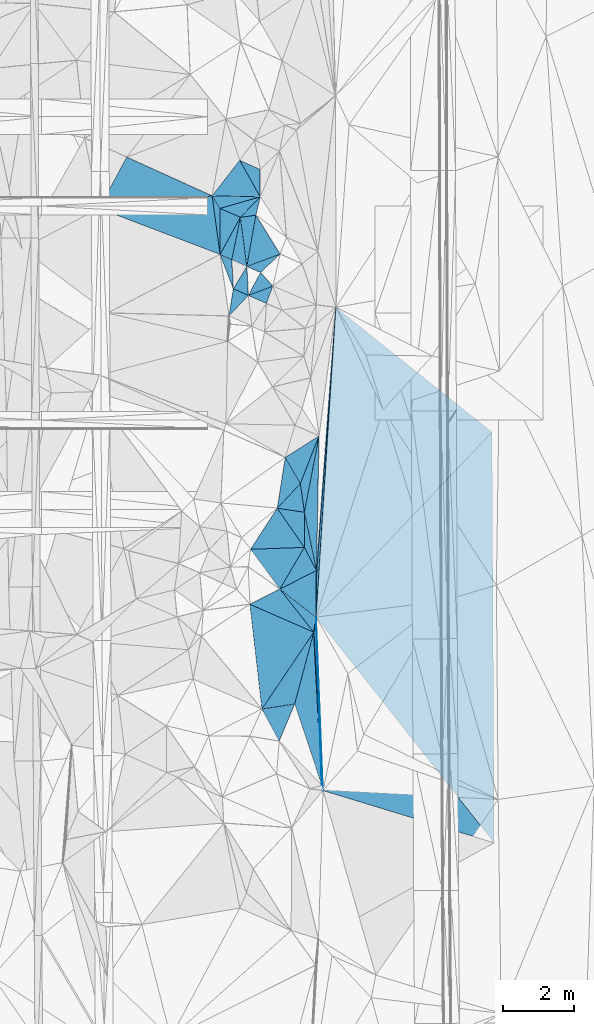
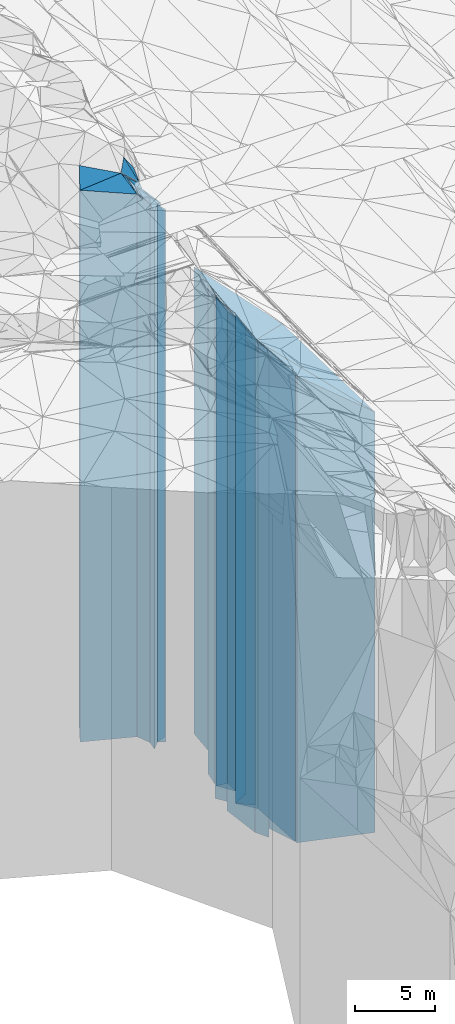
# One storey, part 213 of 275: 42 plates.
"""IFC2X3 building model written with IfcOpenShell, lengths in millimetres."""

from ifc_helpers import new_model, si_unit, frame, origin_with_axes, place, context, subcontext, project, spatial, faceted_brep, material, type_object, element, save


model = new_model("IFC2X3")

# Units and contexts
model_context = context("Model", 3, precision=1e-05, world=origin_with_axes())
body_context = subcontext(model_context, "Body", "Model", "MODEL_VIEW")
ifc_project = project(units=[si_unit("LENGTHUNIT", "METRE", prefix="MILLI"), si_unit("AREAUNIT", "SQUARE_METRE"), si_unit("VOLUMEUNIT", "CUBIC_METRE"), si_unit("MASSUNIT", "GRAM", prefix="KILO"), si_unit("TIMEUNIT", "SECOND"), si_unit("PLANEANGLEUNIT", "RADIAN"), si_unit("SOLIDANGLEUNIT", "STERADIAN"), si_unit("THERMODYNAMICTEMPERATUREUNIT", "DEGREE_CELSIUS"), si_unit("LUMINOUSINTENSITYUNIT", "LUMEN")], contexts=[model_context])

# Site, building, storey
site_placement = place(None, origin_with_axes())
site = spatial("IfcSite", under=ifc_project, at=site_placement, CompositionType="ELEMENT")
building_placement = place(site_placement, origin_with_axes())
building = spatial("IfcBuilding", under=site, at=building_placement, Name="Undefined", CompositionType="ELEMENT")
storey_placement = place(building_placement, origin_with_axes())
storey = spatial("IfcBuildingStorey", under=building, at=storey_placement, Name="Undefined", CompositionType="ELEMENT", Elevation=0.0)

# Plates
ifc_material = material()
plate_type_1 = type_object("IfcPlateType", PredefinedType="NOTDEFINED")
plate_1_placement = place(storey_placement, frame((-97784.8151827176, 54771.5599347121, 23881.5), z_axis=(0.999216150109017, 0.0395864290043219, 0.0), x_axis=(0.0395864290043196, -0.999216150109017, 0.0)))
element("IfcPlate", 1, at=plate_1_placement, inside=storey, type_object=plate_type_1, material=ifc_material, Name="00", context=body_context, shape_type="Brep", body=[
    faceted_brep([(-7.27595761418343e-12, -19471.5, -1.45519152283669e-11), (6510.81298828126, -16053.5, 4737.36474609374), (6510.81298828126, 16053.5, 4737.36474609374), (-7.27595761418343e-12, 16053.5, -1.45519152283669e-11), (4857.63916015624, -19589.5, 5.19503373652697e-09), (4857.63916015624, 16053.5, 5.19503373652697e-09)], [[[0, 1, 2, 3]], [[1, 4, 5, 2]], [[4, 0, 3, 5]], [[5, 3, 2]], [[4, 1, 0]]]),
])
plate_type_2 = type_object("IfcPlateType", PredefinedType="NOTDEFINED")
plate_2_placement = place(storey_placement, frame((-100694.13603594, 66576.3619310611, 28894.0), z_axis=(-0.412888259116076, -0.910781689256046, 0.0), x_axis=(-0.910781689256047, 0.412888259116073, 0.0)))
element("IfcPlate", 2, at=plate_2_placement, inside=storey, type_object=plate_type_2, material=ifc_material, Name="00", context=body_context, shape_type="Brep", body=[
    faceted_brep([(0.0, -21066.0, -7.27595761418343e-12), (2740.78808593749, -21086.0, 1628.275390625), (2740.78808593749, 21066.0, 1628.275390625), (0.0, 21066.0, 0.0), (2627.5654296875, -21836.0, -5.5297277867794e-09), (2627.5654296875, 21066.0, -5.5297277867794e-09)], [[[0, 1, 2, 3]], [[1, 4, 5, 2]], [[4, 0, 3, 5]], [[5, 3, 2]], [[4, 1, 0]]]),
])
plate_type_3 = type_object("IfcPlateType", PredefinedType="NOTDEFINED")
plate_3_placement = place(storey_placement, frame((-99347.3942306218, 67313.984130977, 28284.0), z_axis=(-0.4125032760391, -0.910956117086334, 0.0), x_axis=(-0.91095611708634, 0.412503276039087, 0.0)))
element("IfcPlate", 3, at=plate_3_placement, inside=storey, type_object=plate_type_3, material=ifc_material, Name="00", context=body_context, shape_type="Brep", body=[
    faceted_brep([(1.45519152283669e-11, -21166.0, 0.0), (-315.396667480469, -20456.0, 697.585083007813), (-315.396667480469, 20456.0, 697.585083007813), (1.45519152283669e-11, 20456.0, 0.0), (630.317382812515, -22026.0, 3.87808540835977e-09), (630.317382812515, 20456.0, 3.87808540835977e-09)], [[[0, 1, 2, 3]], [[1, 4, 5, 2]], [[4, 0, 3, 5]], [[5, 3, 2]], [[4, 1, 0]]]),
])
plate_type_4 = type_object("IfcPlateType", PredefinedType="NOTDEFINED")
plate_4_placement = place(storey_placement, frame((-99903.3110214234, 65974.7841751434, 28244.0), z_axis=(-0.137581187998973, 0.990490492992634, 0.0), x_axis=(0.990490492992633, 0.137581187998979, 0.0)))
element("IfcPlate", 4, at=plate_4_placement, inside=storey, type_object=plate_type_4, material=ifc_material, Name="00", context=body_context, shape_type="Brep", body=[
    faceted_brep([(0.0, -20696.0, 0.0), (629.111389160142, -20496.0, 491.750823974638), (629.111389160142, 20416.0, 491.750823974638), (-1.45519152283669e-11, 20416.0, 1.45519152283669e-11), (436.806579589844, -20416.0, -1.81898940354586e-09), (436.806579589844, 20416.0, -1.81898940354586e-09)], [[[0, 1, 2, 3]], [[1, 4, 5, 2]], [[4, 0, 3, 5]], [[5, 3, 2]], [[4, 1, 0]]]),
])
plate_type_5 = type_object("IfcPlateType", PredefinedType="NOTDEFINED")
plate_5_placement = place(storey_placement, frame((-103862.691421568, 66224.9977777885, 28549.0), z_axis=(0.355296883957819, 0.934753509889032, 0.0), x_axis=(0.934753509889031, -0.35529688395782, 0.0)))
element("IfcPlate", 5, at=plate_5_placement, inside=storey, type_object=plate_type_5, material=ifc_material, Name="00", context=body_context, shape_type="Brep", body=[
    faceted_brep([(0.0, -21431.0, 0.0), (2836.97973632813, -21411.0, 1454.21667480469), (2836.97973632813, 20721.0, 1454.21667480469), (0.0, 20721.0, 0.0), (3627.51977539061, -20721.0, -1.80370989255607e-08), (3627.51977539061, 20721.0, -1.80370989255607e-08)], [[[0, 1, 2, 3]], [[1, 4, 5, 2]], [[4, 0, 3, 5]], [[5, 3, 2]], [[4, 1, 0]]]),
])
plate_type_6 = type_object("IfcPlateType", PredefinedType="NOTDEFINED")
plate_6_placement = place(storey_placement, frame((-100471.854542837, 64936.1512928125, 28549.0), z_axis=(-0.999999226371022, -0.00124388800045875, 0.0), x_axis=(-0.0012438880004584, 0.999999226371022, 0.0)))
element("IfcPlate", 6, at=plate_6_placement, inside=storey, type_object=plate_type_6, material=ifc_material, Name="00", context=body_context, shape_type="Brep", body=[
    faceted_brep([(1.45519152283669e-11, -20721.0, 0.0), (1640.48583984376, -21411.0, 220.241088867202), (1640.48583984376, 20721.0, 220.241088867202), (0.0, 20721.0, 0.0), (1289.49597167969, -21201.0, -1.16415321826935e-09), (1289.49597167969, 20721.0, -1.16415321826935e-09)], [[[0, 1, 2, 3]], [[1, 4, 5, 2]], [[4, 0, 3, 5]], [[5, 3, 2]], [[4, 1, 0]]]),
])
plate_type_7 = type_object("IfcPlateType", PredefinedType="NOTDEFINED")
plate_7_placement = place(storey_placement, frame((-99921.5857039729, 67573.9921153368, 28284.0), z_axis=(0.790650244354482, -0.612268071274501, 0.0), x_axis=(-0.612268071274505, -0.790650244354479, 0.0)))
element("IfcPlate", 7, at=plate_7_placement, inside=storey, type_object=plate_type_7, material=ifc_material, Name="00", context=body_context, shape_type="Brep", body=[
    faceted_brep([(1.45519152283669e-11, -22026.0, 0.0), (459.58721923829, -20456.0, 1081.5634765625), (459.58721923829, 20456.0, 1081.5634765625), (1.45519152283669e-11, 20456.0, 0.0), (1261.78442382811, -21676.0, 6.54836185276508e-10), (1261.78442382811, 20456.0, 6.54836185276508e-10)], [[[0, 1, 2, 3]], [[1, 4, 5, 2]], [[4, 0, 3, 5]], [[5, 3, 2]], [[4, 1, 0]]]),
])
plate_type_8 = type_object("IfcPlateType", PredefinedType="NOTDEFINED")
plate_8_placement = place(storey_placement, frame((-99722.1516882737, 64600.6730821044, 27944.0), z_axis=(-0.348327813066436, 0.937372783178792, 0.0), x_axis=(0.937372783178792, 0.348327813066436, 0.0)))
element("IfcPlate", 8, at=plate_8_placement, inside=storey, type_object=plate_type_8, material=ifc_material, Name="00", context=body_context, shape_type="Brep", body=[
    faceted_brep([(0.0, -21066.0, -7.27595761418343e-12), (735.317443847627, -20716.0, 1256.78491210938), (735.317443847627, 20116.0, 1256.78491210938), (0.0, 20116.0, 0.0), (991.816528320313, -20116.0, -3.24507709592581e-09), (991.816528320313, 20116.0, -3.24507709592581e-09)], [[[0, 1, 2, 3]], [[1, 4, 5, 2]], [[4, 0, 3, 5]], [[5, 3, 2]], [[4, 1, 0]]]),
])
plate_type_9 = type_object("IfcPlateType", PredefinedType="NOTDEFINED")
plate_9_placement = place(storey_placement, frame((-99470.6582434293, 66034.8805452004, 28244.0), z_axis=(0.137581187998987, -0.990490492992632, 0.0), x_axis=(-0.990490492992625, -0.137581187999038, 0.0)))
element("IfcPlate", 9, at=plate_9_placement, inside=storey, type_object=plate_type_9, material=ifc_material, Name="00", context=body_context, shape_type="Brep", body=[
    faceted_brep([(0.0, -20416.0, 1.45519152283669e-11), (446.421844482436, -20766.0, 1385.96813964845), (446.421844482436, 20416.0, 1385.96813964845), (-1.45519152283669e-11, 20416.0, 1.45519152283669e-11), (436.806579589844, -20696.0, -1.84809323400259e-09), (436.806579589844, 20416.0, -1.81898940354586e-09)], [[[0, 1, 2, 3]], [[1, 4, 5, 2]], [[4, 0, 3, 5]], [[5, 3, 2]], [[4, 1, 0]]]),
])
plate_type_10 = type_object("IfcPlateType", PredefinedType="NOTDEFINED")
plate_10_placement = place(storey_placement, frame((-99347.8378395339, 66548.4125776842, 28284.0), z_axis=(-0.0207556779940249, -0.999784577712123, 0.0), x_axis=(-0.999784577712123, 0.0207556779940275, 0.0)))
element("IfcPlate", 10, at=plate_10_placement, inside=storey, type_object=plate_type_10, material=ifc_material, Name="00", context=body_context, shape_type="Brep", body=[
    faceted_brep([(0.0, -20456.0, 1.45519152283669e-11), (1118.67895507813, -21466.0, 346.059753417954), (1118.67895507813, 20456.0, 346.059753417954), (1.45519152283669e-11, 20456.0, 0.0), (1346.58825683595, -21676.0, -7.99627741798759e-09), (1346.58825683595, 20456.0, -7.99627741798759e-09)], [[[0, 1, 2, 3]], [[1, 4, 5, 2]], [[4, 0, 3, 5]], [[5, 3, 2]], [[4, 1, 0]]]),
])
plate_type_11 = type_object("IfcPlateType", PredefinedType="NOTDEFINED")
plate_11_placement = place(storey_placement, frame((-100473.45853205, 66225.6463208055, 28284.0), z_axis=(0.402734903136701, 0.915316665310685, 0.0), x_axis=(0.915316665310686, -0.402734903136699, 0.0)))
element("IfcPlate", 11, at=plate_11_placement, inside=storey, type_object=plate_type_11, material=ifc_material, Name="00", context=body_context, shape_type="Brep", body=[
    faceted_brep([(7.27595761418343e-12, -21466.0, 0.0), (900.310119628921, -20456.0, 748.760070800792), (900.310119628921, 20456.0, 748.760070800792), (1.45519152283669e-11, 20456.0, 0.0), (622.896484375, -20656.0, -3.67799657396972e-09), (622.896484375, 20456.0, -3.67799657396972e-09)], [[[0, 1, 2, 3]], [[1, 4, 5, 2]], [[4, 0, 3, 5]], [[5, 3, 2]], [[4, 1, 0]]]),
])
plate_type_12 = type_object("IfcPlateType", PredefinedType="NOTDEFINED")
plate_12_placement = place(storey_placement, frame((-100101.055575703, 63973.9100933349, 28404.0), z_axis=(-0.998659062034093, -0.0517694680017656, 0.0), x_axis=(-0.0517694680017691, 0.998659062034093, 0.0)))
element("IfcPlate", 12, at=plate_12_placement, inside=storey, type_object=plate_type_12, material=ifc_material, Name="00", context=body_context, shape_type="Brep", body=[
    faceted_brep([(0.0, -20576.0, 1.45519152283669e-11), (980.14697265625, -20866.0, 320.487030029311), (980.14697265625, 20576.0, 320.487030029311), (0.0, 20576.0, 1.45519152283669e-11), (813.449462890625, -20606.0, -1.86264514923096e-09), (813.449462890625, 20576.0, -1.86264514923096e-09)], [[[0, 1, 2, 3]], [[1, 4, 5, 2]], [[4, 0, 3, 5]], [[5, 3, 2]], [[4, 1, 0]]]),
])
plate_type_13 = type_object("IfcPlateType", PredefinedType="NOTDEFINED")
plate_13_placement = place(storey_placement, frame((-100471.854542837, 64936.1512928125, 28384.0), z_axis=(0.414902247044911, 0.90986599309848, 0.0), x_axis=(0.909865993098482, -0.414902247044907, 0.0)))
element("IfcPlate", 13, at=plate_13_placement, inside=storey, type_object=plate_type_13, material=ifc_material, Name="00", context=body_context, shape_type="Brep", body=[
    faceted_brep([(-1.45519152283669e-11, -20886.0, -1.09139364212751e-11), (86.3673019408889, -20556.0, 1180.90673828125), (86.3673019408889, 20556.0, 1180.90673828125), (-1.45519152283669e-11, 20556.0, 0.0), (361.247833251939, -20626.0, 5.71162672713399e-10), (361.247833251939, 20556.0, 5.71162672713399e-10)], [[[0, 1, 2, 3]], [[1, 4, 5, 2]], [[4, 0, 3, 5]], [[5, 3, 2]], [[4, 1, 0]]]),
])
plate_type_14 = type_object("IfcPlateType", PredefinedType="NOTDEFINED")
plate_14_placement = place(storey_placement, frame((-99903.3110214234, 65974.7841751434, 28384.0), z_axis=(-0.402734903136704, -0.915316665310683, 0.0), x_axis=(-0.915316665310686, 0.402734903136699, 0.0)))
element("IfcPlate", 14, at=plate_14_placement, inside=storey, type_object=plate_type_14, material=ifc_material, Name="00", context=body_context, shape_type="Brep", body=[
    faceted_brep([(-7.27595761418343e-12, -20556.0, 0.0), (102.103645324707, -20886.0, 1179.65026855468), (102.103645324707, 20556.0, 1179.65026855468), (-1.45519152283669e-11, 20556.0, 0.0), (622.896484375, -21366.0, -3.68163455277681e-09), (622.896484375, 20556.0, -3.68163455277681e-09)], [[[0, 1, 2, 3]], [[1, 4, 5, 2]], [[4, 0, 3, 5]], [[5, 3, 2]], [[4, 1, 0]]]),
])
plate_type_15 = type_object("IfcPlateType", PredefinedType="NOTDEFINED")
plate_15_placement = place(storey_placement, frame((-99903.3110214234, 65974.7841751434, 28384.0), z_axis=(0.98023765730639, -0.197823495061836, 0.0), x_axis=(-0.19782349506183, -0.980237657306391, 0.0)))
element("IfcPlate", 15, at=plate_15_placement, inside=storey, type_object=plate_type_15, material=ifc_material, Name="00", context=body_context, shape_type="Brep", body=[
    faceted_brep([(-7.27595761418343e-12, -20556.0, 0.0), (1311.11791992186, -20626.0, 449.41064453125), (1311.11791992186, 20556.0, 449.41064453125), (-1.45519152283669e-11, 20556.0, 0.0), (1212.47680664063, -20626.0, -4.32191882282496e-09), (1212.47680664063, 20556.0, -4.32191882282496e-09)], [[[0, 1, 2, 3]], [[1, 4, 5, 2]], [[4, 0, 3, 5]], [[5, 3, 2]], [[4, 1, 0]]]),
])
plate_type_16 = type_object("IfcPlateType", PredefinedType="NOTDEFINED")
plate_16_placement = place(storey_placement, frame((-99680.0398434437, 63788.3144220748, 27899.0), z_axis=(-0.353751427002512, 0.935339472006654, 0.0), x_axis=(0.935339472006654, 0.353751427002513, 0.0)))
element("IfcPlate", 16, at=plate_16_placement, inside=storey, type_object=plate_type_16, material=ifc_material, Name="00", context=body_context, shape_type="Brep", body=[
    faceted_brep([(0.0, -21031.0, 0.0), (544.525634765625, -20541.0, 480.512054443345), (544.525634765625, 20071.0, 480.512054443345), (-7.27595761418343e-12, 20071.0, 0.0), (731.095092773438, -20071.0, 1.41153577715158e-09), (731.095092773438, 20071.0, 1.41153577715158e-09)], [[[0, 1, 2, 3]], [[1, 4, 5, 2]], [[4, 0, 3, 5]], [[5, 3, 2]], [[4, 1, 0]]]),
])
plate_type_17 = type_object("IfcPlateType", PredefinedType="NOTDEFINED")
plate_17_placement = place(storey_placement, frame((-98792.4498808621, 64946.150359643, 27944.0), z_axis=(0.348327813066452, -0.937372783178786, 0.0), x_axis=(-0.93737278317879, -0.348327813066441, 0.0)))
element("IfcPlate", 17, at=plate_17_placement, inside=storey, type_object=plate_type_17, material=ifc_material, Name="00", context=body_context, shape_type="Brep", body=[
    faceted_brep([(0.0, -20116.0, 0.0), (693.575866699219, -20496.0, 292.493621826157), (693.575866699219, 20116.0, 292.493621826157), (0.0, 20116.0, 0.0), (991.816528320298, -21066.0, -3.23052518069744e-09), (991.816528320313, 20116.0, -3.24507709592581e-09)], [[[0, 1, 2, 3]], [[1, 4, 5, 2]], [[4, 0, 3, 5]], [[5, 3, 2]], [[4, 1, 0]]]),
])
plate_type_18 = type_object("IfcPlateType", PredefinedType="NOTDEFINED")
plate_18_placement = place(storey_placement, frame((-100222.323223911, 63209.5841435608, 28369.0), z_axis=(-0.729710981343988, 0.683755719322328, 0.0), x_axis=(0.683755719322321, 0.729710981343995, 0.0)))
element("IfcPlate", 18, at=plate_18_placement, inside=storey, type_object=plate_type_18, material=ifc_material, Name="00", context=body_context, shape_type="Brep", body=[
    faceted_brep([(0.0, -20541.0, 0.0), (640.654479980476, -20611.0, 434.121917724609), (640.654479980476, 20541.0, 434.121917724609), (0.0, 20541.0, 0.0), (793.09521484375, -20561.0, -3.20142135024071e-10), (793.09521484375, 20541.0, -3.20142135024071e-10)], [[[0, 1, 2, 3]], [[1, 4, 5, 2]], [[4, 0, 3, 5]], [[5, 3, 2]], [[4, 1, 0]]]),
])
plate_type_19 = type_object("IfcPlateType", PredefinedType="NOTDEFINED")
plate_19_placement = place(storey_placement, frame((-99722.1516882737, 64600.6730821044, 28379.0), z_axis=(0.855773744845277, -0.517350265906466, 0.0), x_axis=(-0.517350265906468, -0.855773744845276, 0.0)))
element("IfcPlate", 19, at=plate_19_placement, inside=storey, type_object=plate_type_19, material=ifc_material, Name="00", context=body_context, shape_type="Brep", body=[
    faceted_brep([(-1.45519152283669e-11, -20631.0, 1.45519152283669e-11), (673.408630371093, -20551.0, 456.312194824204), (673.408630371093, 20551.0, 456.312194824204), (-7.27595761418343e-12, 20551.0, 0.0), (732.393310546881, -20601.0, 1.09139364212751e-09), (732.393310546881, 20551.0, 1.09139364212751e-09)], [[[0, 1, 2, 3]], [[1, 4, 5, 2]], [[4, 0, 3, 5]], [[5, 3, 2]], [[4, 1, 0]]]),
])
plate_type_20 = type_object("IfcPlateType", PredefinedType="NOTDEFINED")
plate_20_placement = place(storey_placement, frame((-99680.0398434437, 63788.3144220748, 27899.0), z_axis=(0.408049615224531, 0.912959753502372, 0.0), x_axis=(0.912959753502374, -0.408049615224527, 0.0)))
element("IfcPlate", 20, at=plate_20_placement, inside=storey, type_object=plate_type_20, material=ifc_material, Name="00", context=body_context, shape_type="Brep", body=[
    faceted_brep([(0.0, -21031.0, 0.0), (518.769836425752, -20071.0, 515.148376464836), (518.769836425752, 20071.0, 515.148376464836), (-7.27595761418343e-12, 20071.0, 0.0), (552.268066406235, -20581.0, 2.48110154643655e-09), (552.268066406235, 20071.0, 2.48110154643655e-09)], [[[0, 1, 2, 3]], [[1, 4, 5, 2]], [[4, 0, 3, 5]], [[5, 3, 2]], [[4, 1, 0]]]),
])
plate_type_21 = type_object("IfcPlateType", PredefinedType="NOTDEFINED")
plate_21_placement = place(storey_placement, frame((-97699.4877933211, 59853.1125750592, 25644.0), z_axis=(0.982095436258236, -0.188384060049531, 0.0), x_axis=(-0.188384060049532, -0.982095436258236, 0.0)))
element("IfcPlate", 21, at=plate_21_placement, inside=storey, type_object=plate_type_21, material=ifc_material, Name="00", context=body_context, shape_type="Brep", body=[
    faceted_brep([(0.0, -17936.0, -1.45519152283669e-11), (3716.75537109374, -17816.0, 640.492065429673), (3716.75537109374, 17816.0, 640.492065429673), (-5.45696821063757e-12, 17816.0, 0.0), (2177.54443359375, -18186.0, -2.06637196242809e-09), (2177.54443359375, 17816.0, -2.06637196242809e-09)], [[[0, 1, 2, 3]], [[1, 4, 5, 2]], [[4, 0, 3, 5]], [[5, 3, 2]], [[4, 1, 0]]]),
])
plate_type_22 = type_object("IfcPlateType", PredefinedType="NOTDEFINED")
plate_22_placement = place(storey_placement, frame((-98869.9844511925, 57826.6778798589, 25784.0), z_axis=(-0.730075644744319, 0.683366338760673, 0.0), x_axis=(0.683366338760675, 0.730075644744317, 0.0)))
element("IfcPlate", 22, at=plate_22_placement, inside=storey, type_object=plate_type_22, material=ifc_material, Name="00", context=body_context, shape_type="Brep", body=[
    faceted_brep([(-3.63797880709171e-12, -19356.0, 0.0), (1191.33496093751, -19536.0, 808.220825195327), (1191.33496093751, 17956.0, 808.220825195327), (-3.63797880709171e-12, 17956.0, 0.0), (945.409973144528, -17956.0, -2.459273673594e-09), (945.409973144528, 17956.0, -2.459273673594e-09)], [[[0, 1, 2, 3]], [[1, 4, 5, 2]], [[4, 0, 3, 5]], [[5, 3, 2]], [[4, 1, 0]]]),
])
plate_type_23 = type_object("IfcPlateType", PredefinedType="NOTDEFINED")
plate_23_placement = place(storey_placement, frame((-98223.9231053053, 58516.8986687014, 25784.0), z_axis=(0.730075644744319, -0.683366338760673, 0.0), x_axis=(-0.683366338760671, -0.730075644744321, 0.0)))
element("IfcPlate", 23, at=plate_23_placement, inside=storey, type_object=plate_type_23, material=ifc_material, Name="00", context=body_context, shape_type="Brep", body=[
    faceted_brep([(2.18278728425503e-11, -17956.0, 0.0), (507.716247558623, -18046.0, 631.683654785171), (507.716247558623, 17956.0, 631.683654785171), (-3.63797880709171e-12, 17956.0, 0.0), (945.409973144553, -19356.0, -2.459273673594e-09), (945.409973144528, 17956.0, -2.459273673594e-09)], [[[0, 1, 2, 3]], [[1, 4, 5, 2]], [[4, 0, 3, 5]], [[5, 3, 2]], [[4, 1, 0]]]),
])
plate_type_24 = type_object("IfcPlateType", PredefinedType="NOTDEFINED")
plate_24_placement = place(storey_placement, frame((-98645.928522441, 59248.7534547814, 25704.0), z_axis=(0.866297515721974, 0.49952839183968, 0.0), x_axis=(0.499528391839682, -0.866297515721973, 0.0)))
element("IfcPlate", 24, at=plate_24_placement, inside=storey, type_object=plate_type_24, material=ifc_material, Name="00", context=body_context, shape_type="Brep", body=[
    faceted_brep([(7.27595761418343e-12, -19616.0, -1.45519152283669e-11), (-50.7807884216309, -17876.0, 1121.79382324217), (-50.7807884216309, 17876.0, 1121.79382324217), (0.0, 17876.0, 1.45519152283669e-11), (844.807678222656, -18036.0, -5.5297277867794e-10), (844.807678222656, 17876.0, -5.5297277867794e-10)], [[[0, 1, 2, 3]], [[1, 4, 5, 2]], [[4, 0, 3, 5]], [[5, 3, 2]], [[4, 1, 0]]]),
])
plate_type_25 = type_object("IfcPlateType", PredefinedType="NOTDEFINED")
plate_25_placement = place(storey_placement, frame((-98109.7024641429, 57714.556070348, 25829.0), z_axis=(-0.145895997045634, -0.989299933309439, 0.0), x_axis=(-0.989299933309439, 0.145895997045634, 0.0)))
element("IfcPlate", 25, at=plate_25_placement, inside=storey, type_object=plate_type_25, material=ifc_material, Name="00", context=body_context, shape_type="Brep", body=[
    faceted_brep([(1.45519152283669e-11, -18001.0, 0.0), (-141.833816528291, -18221.0, 974.619506835938), (-141.833816528291, 18001.0, 974.619506835938), (1.45519152283669e-11, 18001.0, 0.0), (768.505065917983, -19311.0, 2.459273673594e-09), (768.505065917983, 18001.0, 2.459273673594e-09)], [[[0, 1, 2, 3]], [[1, 4, 5, 2]], [[4, 0, 3, 5]], [[5, 3, 2]], [[4, 1, 0]]]),
])
plate_type_26 = type_object("IfcPlateType", PredefinedType="NOTDEFINED")
plate_26_placement = place(storey_placement, frame((-99618.4586970826, 56675.6842642209, 25939.0), z_axis=(-0.0358045910024758, 0.999358810069309, 0.0), x_axis=(0.999358810069309, 0.0358045910024758, 0.0)))
element("IfcPlate", 26, at=plate_26_placement, inside=storey, type_object=plate_type_26, material=ifc_material, Name="00", context=body_context, shape_type="Brep", body=[
    faceted_brep([(0.0, -20131.0, 7.27595761418343e-12), (789.205200195313, -19201.0, 1123.45678710938), (789.205200195313, 18111.0, 1123.45678710938), (-1.45519152283669e-11, 18111.0, 0.0), (1507.84619140625, -18111.0, 5.6170392781496e-09), (1507.84619140625, 18111.0, 5.6170392781496e-09)], [[[0, 1, 2, 3]], [[1, 4, 5, 2]], [[4, 0, 3, 5]], [[5, 3, 2]], [[4, 1, 0]]]),
])
plate_type_27 = type_object("IfcPlateType", PredefinedType="NOTDEFINED")
plate_27_placement = place(storey_placement, frame((-98223.9231053053, 58516.8986687014, 25704.0), z_axis=(0.990018427993595, 0.140937972999089, 0.0), x_axis=(0.140937972999085, -0.990018427993595, 0.0)))
element("IfcPlate", 27, at=plate_27_placement, inside=storey, type_object=plate_type_27, material=ifc_material, Name="00", context=body_context, shape_type="Brep", body=[
    faceted_brep([(-1.45519152283669e-11, -18036.0, 1.45519152283669e-11), (-1248.96350097658, -17876.0, 707.523925781265), (-1248.96350097658, 17876.0, 707.523925781265), (0.0, 17876.0, 1.45519152283669e-11), (810.432006835923, -18126.0, -8.58562998473644e-10), (810.432006835923, 17876.0, -8.58562998473644e-10)], [[[0, 1, 2, 3]], [[1, 4, 5, 2]], [[4, 0, 3, 5]], [[5, 3, 2]], [[4, 1, 0]]]),
])
plate_type_28 = type_object("IfcPlateType", PredefinedType="NOTDEFINED")
plate_28_placement = place(storey_placement, frame((-98798.1485683479, 55562.3149217764, 25644.0), z_axis=(-0.451499591824368, 0.892271325652925, 0.0), x_axis=(0.892271325652921, 0.451499591824378, 0.0)))
element("IfcPlate", 28, at=plate_28_placement, inside=storey, type_object=plate_type_28, material=ifc_material, Name="00", context=body_context, shape_type="Brep", body=[
    faceted_brep([(1.45519152283669e-11, -19586.0, -1.45519152283669e-11), (1139.66723632814, -18406.0, 731.613586425781), (1139.66723632814, 17816.0, 731.613586425781), (-5.45696821063757e-12, 17816.0, 0.0), (1151.56420898439, -17816.0, -2.61934474110603e-10), (1151.56420898439, 17816.0, -2.61934474110603e-10)], [[[0, 1, 2, 3]], [[1, 4, 5, 2]], [[4, 0, 3, 5]], [[5, 3, 2]], [[4, 1, 0]]]),
])
plate_type_29 = type_object("IfcPlateType", PredefinedType="NOTDEFINED")
plate_29_placement = place(storey_placement, frame((-98109.7024641429, 57714.556070348, 25644.0), z_axis=(0.999998184140672, -0.00190570600026582, 0.0), x_axis=(-0.0019057060002739, -0.999998184140672, 0.0)))
element("IfcPlate", 29, at=plate_29_placement, inside=storey, type_object=plate_type_29, material=ifc_material, Name="00", context=body_context, shape_type="Brep", body=[
    faceted_brep([(0.0, -18186.0, 0.0), (1631.66125488281, -17816.0, 342.171661376939), (1631.66125488281, 17816.0, 342.171661376939), (-5.45696821063757e-12, 17816.0, 0.0), (984.885803222656, -18406.0, 1.86264514923096e-09), (984.885803222656, 17816.0, 1.86264514923096e-09)], [[[0, 1, 2, 3]], [[1, 4, 5, 2]], [[4, 0, 3, 5]], [[5, 3, 2]], [[4, 1, 0]]]),
])
plate_type_30 = type_object("IfcPlateType", PredefinedType="NOTDEFINED")
plate_30_placement = place(storey_placement, frame((-98111.5793668439, 56729.6720785824, 25939.0), z_axis=(0.0358045910023944, -0.999358810069312, 0.0), x_axis=(-0.999358810069309, -0.0358045910024823, 0.0)))
element("IfcPlate", 30, at=plate_30_placement, inside=storey, type_object=plate_type_30, material=ifc_material, Name="00", context=body_context, shape_type="Brep", body=[
    faceted_brep([(0.0, -18111.0, 0.0), (727.925720214829, -19291.0, 1142.02636718749), (727.925720214829, 18111.0, 1142.02636718749), (-1.45519152283669e-11, 18111.0, 0.0), (1507.84619140625, -20131.0, 5.59521140530705e-09), (1507.84619140625, 18111.0, 5.6170392781496e-09)], [[[0, 1, 2, 3]], [[1, 4, 5, 2]], [[4, 0, 3, 5]], [[5, 3, 2]], [[4, 1, 0]]]),
])
plate_type_31 = type_object("IfcPlateType", PredefinedType="NOTDEFINED")
plate_31_placement = place(storey_placement, frame((-97770.6408944681, 56082.2456672783, 25590.5), z_axis=(0.451499591824368, -0.892271325652925, 0.0), x_axis=(-0.892271325652923, -0.451499591824373, 0.0)))
element("IfcPlate", 31, at=plate_31_placement, inside=storey, type_object=plate_type_31, material=ifc_material, Name="00", context=body_context, shape_type="Brep", body=[
    faceted_brep([(-7.27595761418343e-12, -17869.5, 0.0), (604.421386718735, -17762.5, 1163.08764648436), (604.421386718735, 17762.5, 1163.08764648436), (-7.27595761418343e-12, 17762.5, 0.0), (1151.56420898437, -19639.5, -2.7648638933897e-10), (1151.56420898437, 17762.5, -2.7648638933897e-10)], [[[0, 1, 2, 3]], [[1, 4, 5, 2]], [[4, 0, 3, 5]], [[5, 3, 2]], [[4, 1, 0]]]),
])
plate_type_32 = type_object("IfcPlateType", PredefinedType="NOTDEFINED")
plate_32_placement = place(storey_placement, frame((-97848.0562518894, 54353.2555393611, 25590.5), z_axis=(-0.98876390170415, 0.149485606955274, 0.0), x_axis=(0.149485606955263, 0.988763901704151, 0.0)))
element("IfcPlate", 32, at=plate_32_placement, inside=storey, type_object=plate_type_32, material=ifc_material, Name="00", context=body_context, shape_type="Brep", body=[
    faceted_brep([(7.27595761418343e-12, -17949.5, 0.0), (1053.44909667968, -19639.5, 1120.15393066406), (1053.44909667968, 17762.5, 1120.15393066406), (-7.27595761418343e-12, 17762.5, 0.0), (423.057922363289, -17762.5, 2.47382558882236e-10), (423.057922363289, 17762.5, 2.47382558882236e-10)], [[[0, 1, 2, 3]], [[1, 4, 5, 2]], [[4, 0, 3, 5]], [[5, 3, 2]], [[4, 1, 0]]]),
])
plate_type_33 = type_object("IfcPlateType", PredefinedType="NOTDEFINED")
plate_33_placement = place(storey_placement, frame((-97770.6408944681, 56082.2456672783, 25590.5), z_axis=(0.999941529436484, -0.0108137740047223, 0.0), x_axis=(-0.0108137740047156, -0.999941529436484, 0.0)))
element("IfcPlate", 33, at=plate_33_placement, inside=storey, type_object=plate_type_33, material=ifc_material, Name="00", context=body_context, shape_type="Brep", body=[
    faceted_brep([(-7.27595761418343e-12, -17869.5, 0.0), (-7375.60937500001, -17913.5, 460.975250244141), (-7375.60937500001, 17762.5, 460.975250244141), (-7.27595761418343e-12, 17762.5, 0.0), (1310.76232910156, -17762.5, 1.42608769237995e-09), (1310.76232910156, 17762.5, 1.42608769237995e-09)], [[[0, 1, 2, 3]], [[1, 4, 5, 2]], [[4, 0, 3, 5]], [[5, 3, 2]], [[4, 1, 0]]]),
])
plate_type_34 = type_object("IfcPlateType", PredefinedType="NOTDEFINED")
plate_34_placement = place(storey_placement, frame((-99302.0739093872, 52201.4579997015, 25684.0), z_axis=(-0.155087703934303, 0.98790070558148, 0.0), x_axis=(0.987900705581481, 0.155087703934298, 0.0)))
element("IfcPlate", 34, at=plate_34_placement, inside=storey, type_object=plate_type_34, material=ifc_material, Name="00", context=body_context, shape_type="Brep", body=[
    faceted_brep([(0.0, -19716.0, 0.0), (1770.14245605469, -17856.0, 1900.26208496094), (1770.14245605469, 17856.0, 1900.26208496094), (0.0, 17856.0, 0.0), (931.450500488296, -18646.0, 1.28056854009628e-09), (931.450500488296, 17856.0, 1.28056854009628e-09)], [[[0, 1, 2, 3]], [[1, 4, 5, 2]], [[4, 0, 3, 5]], [[5, 3, 2]], [[4, 1, 0]]]),
])
plate_type_35 = type_object("IfcPlateType", PredefinedType="NOTDEFINED")
plate_35_placement = place(storey_placement, frame((-97848.0562518894, 54353.2555393611, 25684.0), z_axis=(0.96640897930399, -0.257009114080844, 0.0), x_axis=(-0.25700911408084, -0.966408979303991, 0.0)))
element("IfcPlate", 35, at=plate_35_placement, inside=storey, type_object=plate_type_35, material=ifc_material, Name="00", context=body_context, shape_type="Brep", body=[
    faceted_brep([(-3.63797880709171e-12, -17856.0, -2.91038304567337e-11), (4092.8916015625, -17916.0, 1322.70104980467), (4092.8916015625, 17856.0, 1322.70104980467), (0.0, 17856.0, 0.0), (2077.11328124999, -18646.0, 1.74622982740402e-10), (2077.11328124999, 17856.0, 1.74622982740402e-10)], [[[0, 1, 2, 3]], [[1, 4, 5, 2]], [[4, 0, 3, 5]], [[5, 3, 2]], [[4, 1, 0]]]),
])
plate_type_36 = type_object("IfcPlateType", PredefinedType="NOTDEFINED")
plate_36_placement = place(storey_placement, frame((-98798.1485683479, 55562.3149217764, 25684.0), z_axis=(0.452404799933225, -0.891812702868365, 0.0), x_axis=(-0.891812702868366, -0.452404799933223, 0.0)))
element("IfcPlate", 36, at=plate_36_placement, inside=storey, type_object=plate_type_36, material=ifc_material, Name="00", context=body_context, shape_type="Brep", body=[
    faceted_brep([(7.27595761418343e-12, -19546.0, -1.45519152283669e-11), (-300.320129394524, -17856.0, 1508.08081054686), (-300.320129394524, 17856.0, 1508.08081054686), (0.0, 17856.0, 0.0), (941.328857421868, -20576.0, 1.10594555735588e-09), (941.328857421868, 17856.0, 1.10594555735588e-09)], [[[0, 1, 2, 3]], [[1, 4, 5, 2]], [[4, 0, 3, 5]], [[5, 3, 2]], [[4, 1, 0]]]),
])
plate_type_37 = type_object("IfcPlateType", PredefinedType="NOTDEFINED")
plate_37_placement = place(storey_placement, frame((-99302.0739093872, 52201.4579997015, 26079.0), z_axis=(0.880163511092564, 0.474670616049919, 0.0), x_axis=(0.474670616049919, -0.880163511092564, 0.0)))
element("IfcPlate", 37, at=plate_37_placement, inside=storey, type_object=plate_type_37, material=ifc_material, Name="00", context=body_context, shape_type="Brep", body=[
    faceted_brep([(0.0, -19321.0, 0.0), (309.637329101577, -18251.0, 878.478637695313), (309.637329101577, 18251.0, 878.478637695313), (0.0, 18251.0, 0.0), (1023.13244628906, -18541.0, 1.96450855582953e-09), (1023.13244628906, 18251.0, 1.96450855582953e-09)], [[[0, 1, 2, 3]], [[1, 4, 5, 2]], [[4, 0, 3, 5]], [[5, 3, 2]], [[4, 1, 0]]]),
])
plate_type_38 = type_object("IfcPlateType", PredefinedType="NOTDEFINED")
plate_38_placement = place(storey_placement, frame((-97848.0562518894, 54353.2555393611, 25684.0), z_axis=(-0.400928765088184, -0.916109232201523, 0.0), x_axis=(-0.916109232201523, 0.400928765088184, 0.0)))
element("IfcPlate", 38, at=plate_38_placement, inside=storey, type_object=plate_type_38, material=ifc_material, Name="00", context=body_context, shape_type="Brep", body=[
    faceted_brep([(-3.63797880709171e-12, -17856.0, -2.91038304567337e-11), (469.321472167983, -19716.0, 2554.23901367188), (469.321472167983, 17856.0, 2554.23901367188), (0.0, 17856.0, 0.0), (1953.45849609375, -20576.0, -1.00480974651873e-08), (1953.45849609375, 17856.0, -1.00480974651873e-08)], [[[0, 1, 2, 3]], [[1, 4, 5, 2]], [[4, 0, 3, 5]], [[5, 3, 2]], [[4, 1, 0]]]),
])
plate_type_39 = type_object("IfcPlateType", PredefinedType="NOTDEFINED")
plate_39_placement = place(storey_placement, frame((-97848.0562518894, 54353.2555393611, 25590.5), z_axis=(0.998614307198052, 0.0526257110104379, 0.0), x_axis=(0.0526257110104367, -0.998614307198052, 0.0)))
element("IfcPlate", 39, at=plate_39_placement, inside=storey, type_object=plate_type_39, material=ifc_material, Name="00", context=body_context, shape_type="Brep", body=[
    faceted_brep([(7.27595761418343e-12, -17949.5, 0.0), (-414.396636962891, -17762.5, 85.1669998168945), (-414.396636962891, 17762.5, 85.1669998168945), (-7.27595761418343e-12, 17762.5, 0.0), (4301.31396484375, -18009.5, -9.60426405072212e-09), (4301.31396484375, 17762.5, -9.60426405072212e-09)], [[[0, 1, 2, 3]], [[1, 4, 5, 2]], [[4, 0, 3, 5]], [[5, 3, 2]], [[4, 1, 0]]]),
])
plate_type_40 = type_object("IfcPlateType", PredefinedType="NOTDEFINED")
plate_40_placement = place(storey_placement, frame((-97621.6965573815, 50057.9020860697, 25590.5), z_axis=(0.979015098103885, 0.203787727021626, 0.0), x_axis=(0.203787727021601, -0.97901509810389, 0.0)))
element("IfcPlate", 40, at=plate_40_placement, inside=storey, type_object=plate_type_40, material=ifc_material, Name="00", context=body_context, shape_type="Brep", body=[
    faceted_brep([(-1.45519152283669e-11, -18009.5, -1.45519152283669e-11), (-4647.98388671874, -17762.5, 800.890014648438), (-4647.98388671874, 17762.5, 800.890014648438), (-7.27595761418343e-12, 17762.5, 0.0), (143.178207397446, -17880.5, -1.30967237055302e-10), (143.178207397446, 17762.5, -1.30967237055302e-10)], [[[0, 1, 2, 3]], [[1, 4, 5, 2]], [[4, 0, 3, 5]], [[5, 3, 2]], [[4, 1, 0]]]),
])
plate_type_41 = type_object("IfcPlateType", PredefinedType="NOTDEFINED")
plate_41_placement = place(storey_placement, frame((-92853.8449081596, 59957.5971647583, 23775.5), z_axis=(-0.624038284921312, -0.781393766901469, 0.0), x_axis=(-0.781393766901469, 0.624038284921312, 0.0)))
element("IfcPlate", 41, at=plate_41_placement, inside=storey, type_object=plate_type_41, material=ifc_material, Name="00", context=body_context, shape_type="Brep", body=[
    faceted_brep([(1.45519152283669e-11, -15947.5, 0.0), (616.743652343765, -19577.5, 7129.45117187501), (616.743652343765, 15947.5, 7129.45117187501), (-1.45519152283669e-11, 15947.5, 5.45696821063757e-12), (5600.36376953126, -19728.5, -9.77161107584834e-09), (5600.36376953124, 15947.5, -9.78070602286607e-09)], [[[0, 1, 2, 3]], [[1, 4, 5, 2]], [[4, 0, 3, 5]], [[5, 3, 2]], [[4, 1, 0]]]),
])
plate_type_42 = type_object("IfcPlateType", PredefinedType="NOTDEFINED")
plate_42_placement = place(storey_placement, frame((-97784.8151827176, 54771.5599347121, 23775.5), z_axis=(0.784679818453341, 0.61990126835814, 0.0), x_axis=(0.619901268358142, -0.78467981845334, 0.0)))
element("IfcPlate", 42, at=plate_42_placement, inside=storey, type_object=plate_type_42, material=ifc_material, Name="00", context=body_context, shape_type="Brep", body=[
    faceted_brep([(0.0, -19577.5, -7.27595761418343e-12), (-1012.66400146486, -15947.5, 7084.06396484374), (-1012.66400146486, 15947.5, 7084.06396484374), (-1.45519152283669e-11, 15947.5, 5.45696821063757e-12), (8051.91357421875, -16159.5, 2.1776941139251e-08), (8051.91357421875, 15947.5, 2.1776941139251e-08)], [[[0, 1, 2, 3]], [[1, 4, 5, 2]], [[4, 0, 3, 5]], [[5, 3, 2]], [[4, 1, 0]]]),
])

save(model, "model.ifc")
